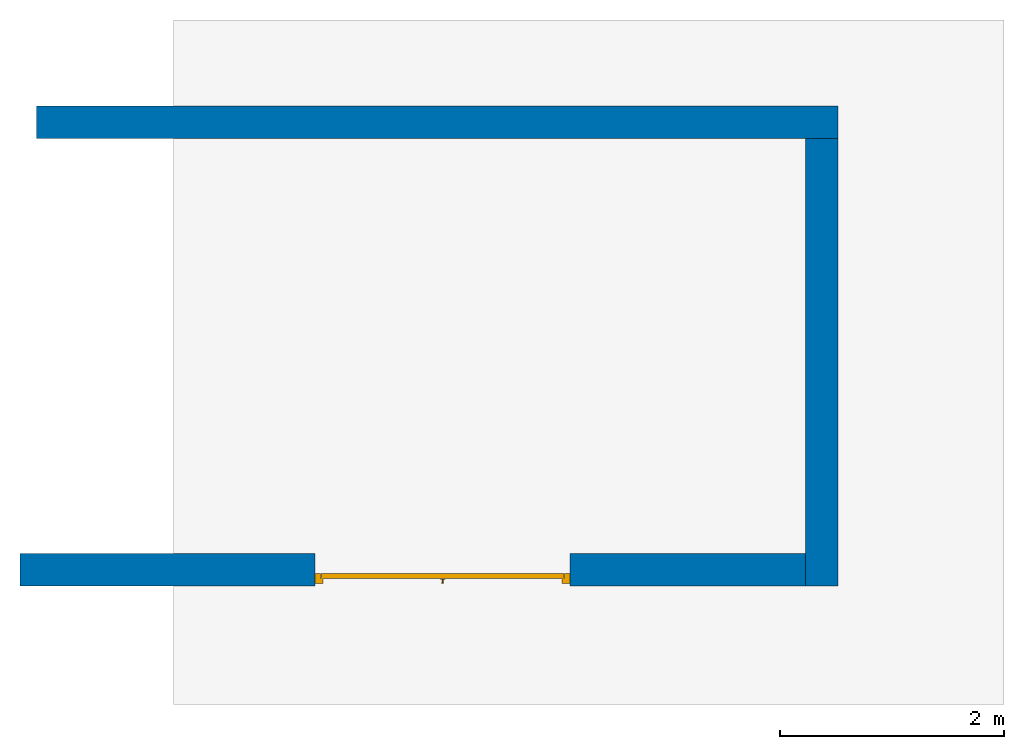
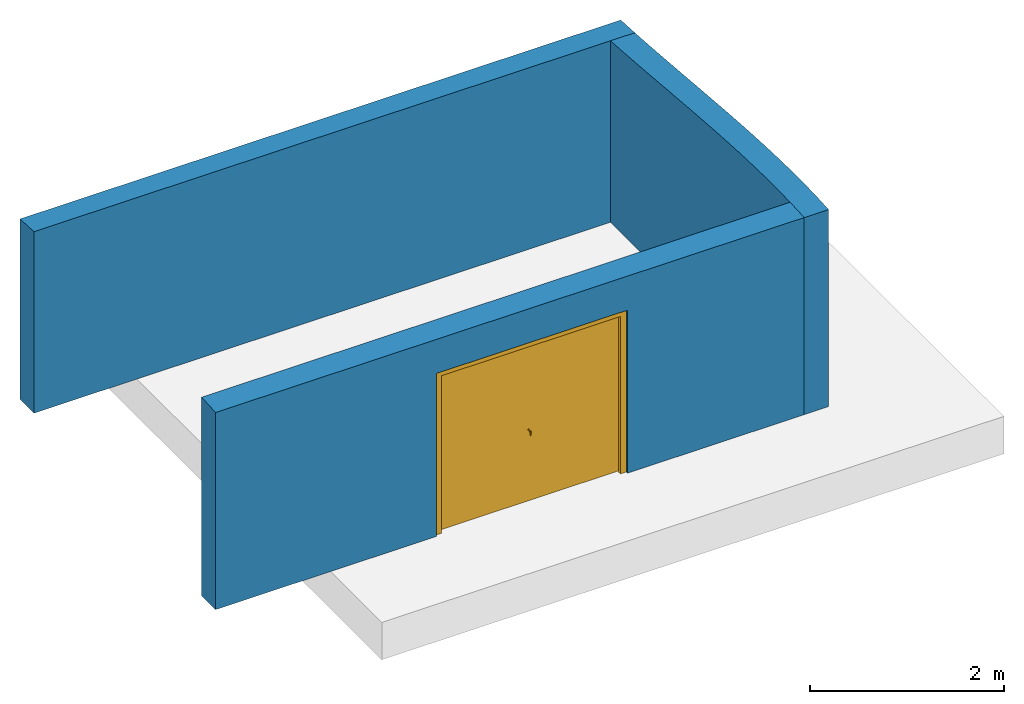
# One storey, part 2 of 2: 3 walls, 1 door, 1 opening.
"""IFC2X3 building model written with IfcOpenShell, lengths in millimetres."""

from ifc_helpers import new_model, entity, si_unit, converted_unit, derived_unit, direction, frame, frame_2d, origin, place, context, subcontext, project, spatial, rectangle, extrude, faceted_brep, source, transform, mapped, material, material_list, type_object, type_shapes, element, fill, save


model = new_model("IFC2X3")

# Units and contexts
model_context = context("Model", 3, precision=0.01, world=origin(), true_north=direction((6.12303176911189e-17, 1.0)))
body_context = subcontext(model_context, "Body", "Model", "MODEL_VIEW")
ifc_project = project(units=[si_unit("LENGTHUNIT", "METRE", prefix="MILLI"), si_unit("AREAUNIT", "SQUARE_METRE"), si_unit("VOLUMEUNIT", "CUBIC_METRE"), converted_unit("PLANEANGLEUNIT", "DEGREE", entity("IfcRatioMeasure", 0.0174532925199433), si_unit("PLANEANGLEUNIT", "RADIAN"), dimensions=[0, 0, 0, 0, 0, 0, 0]), si_unit("MASSUNIT", "GRAM", prefix="KILO"), si_unit("TIMEUNIT", "SECOND"), si_unit("FREQUENCYUNIT", "HERTZ"), si_unit("THERMODYNAMICTEMPERATUREUNIT", "DEGREE_CELSIUS"), derived_unit("THERMALTRANSMITTANCEUNIT", [(si_unit("MASSUNIT", "GRAM", prefix="KILO"), 1), (si_unit("THERMODYNAMICTEMPERATUREUNIT", "KELVIN"), -1), (si_unit("TIMEUNIT", "SECOND"), -3)]), derived_unit("VOLUMETRICFLOWRATEUNIT", [(si_unit("LENGTHUNIT", "METRE"), 3), (si_unit("TIMEUNIT", "SECOND"), -1)]), si_unit("ELECTRICCURRENTUNIT", "AMPERE"), si_unit("ELECTRICVOLTAGEUNIT", "VOLT"), si_unit("POWERUNIT", "WATT"), si_unit("FORCEUNIT", "NEWTON", prefix="KILO"), si_unit("ILLUMINANCEUNIT", "LUX"), si_unit("LUMINOUSFLUXUNIT", "LUMEN"), si_unit("LUMINOUSINTENSITYUNIT", "CANDELA"), derived_unit("USERDEFINED", [(si_unit("MASSUNIT", "GRAM", prefix="KILO"), -1), (si_unit("LENGTHUNIT", "METRE"), -2), (si_unit("TIMEUNIT", "SECOND"), 3), (si_unit("LUMINOUSFLUXUNIT", "LUMEN"), 1)]), derived_unit("LINEARVELOCITYUNIT", [(si_unit("LENGTHUNIT", "METRE"), 1), (si_unit("TIMEUNIT", "SECOND"), -1)]), si_unit("PRESSUREUNIT", "PASCAL"), derived_unit("USERDEFINED", [(si_unit("LENGTHUNIT", "METRE"), -2), (si_unit("MASSUNIT", "GRAM", prefix="KILO"), 1), (si_unit("TIMEUNIT", "SECOND"), -2)])], contexts=[model_context])

# Site, building, storey
site_placement = place(None, origin())
site = spatial("IfcSite", under=ifc_project, at=site_placement, CompositionType="ELEMENT")
building_placement = place(site_placement, origin())
building = spatial("IfcBuilding", under=site, at=building_placement, CompositionType="ELEMENT")
storey_placement = place(building_placement, origin())
storey = spatial("IfcBuildingStorey", under=building, at=storey_placement, Name="Level 0", CompositionType="ELEMENT", Elevation=0.0)

# Walls
ifc_material_1 = material(Name="Brick, Common")
ifc_material_2 = material(Name="Fiberglass Batt")
ifc_material_3 = material(Name="Concrete Masonry Units _Low Density")
ifc_material_4 = material(Name="Plaster")
ifc_material_list_1 = material_list([ifc_material_1, ifc_material_2, ifc_material_3, ifc_material_4])
wall_type = type_object("IfcWallType", PredefinedType="NOTDEFINED")
wall_1_placement = place(storey_placement, frame((7047.64559519153, 1813.63350968312, 0.0)))
element("IfcWall", 1, at=wall_1_placement, inside=storey, type_object=wall_type, material=ifc_material_list_1, context=body_context, shape_type="Brep", body=[
    faceted_brep([(0.0, -145.0, 2281.7914346779), (0.0, -145.0, 0.0), (6855.0, -145.0, 0.0), (7145.0, -145.0, 0.0), (7145.0, -145.0, 2281.7914346779), (6855.0, -145.0, 2281.7914346779), (5394.23421303837, -145.0, 2281.7914346779), (3933.46842607673, -145.0, 2281.7914346779), (2950.10131955755, -145.0, 2281.7914346779), (1966.73421303836, -145.0, 2281.7914346779), (983.367106519185, -145.0, 2281.7914346779), (7145.0, 145.0, 0.0), (0.0, 145.0, 0.0), (0.0, 145.0, 2266.01450915395), (983.367105430462, 145.0, 2266.01450915395), (1966.73421086093, 145.0, 2266.01450915395), (3572.5, 145.0, 2266.01450915395), (5178.26578913908, 145.0, 2266.01450915395), (6161.63289456954, 145.0, 2266.01450915395), (7145.0, 145.0, 2266.01450915395), (0.0, -72.5042682850876, 2277.4048198664), (0.0, -0.0176978591323646, 2273.29703191053), (0.0, 72.4837913931937, 2269.49143553), (7145.0, 72.4955520406726, 2269.49084419756), (7145.0, -0.019433106363573, 2273.2971267219), (7145.0, -72.5178888364432, 2277.40561863594), (1475.0506612011, 1.18072418660527, 2273.23159334814), (2783.83369596127, -0.369299165116482, 2273.31624643556), (5669.94934270946, 6.80500430566447, 2272.92559467043), (4458.30028831694, 9.42253038304246, 2272.78380948582)], [[[0, 1, 2, 3, 4, 5, 6, 7, 8, 9, 10]], [[11, 12, 13, 14, 15, 16, 17, 18, 19]], [[2, 1, 12, 11, 3]], [[1, 0, 20, 21, 22, 13, 12]], [[4, 3, 11, 19, 23, 24, 25]], [[4, 25, 5]], [[26, 9, 27]], [[23, 19, 18]], [[28, 25, 24]], [[15, 26, 27]], [[24, 23, 28]], [[18, 17, 28]], [[14, 26, 15]], [[20, 10, 26]], [[20, 0, 10]], [[10, 9, 26]], [[21, 20, 26]], [[18, 28, 23]], [[27, 16, 15]], [[22, 26, 14]], [[29, 7, 6]], [[22, 14, 13]], [[6, 28, 29]], [[5, 25, 28]], [[22, 21, 26]], [[27, 9, 8, 7]], [[29, 27, 7]], [[28, 17, 29]], [[6, 5, 28]], [[17, 16, 29]], [[27, 29, 16]]]),
])
ifc_material_list_2 = material_list([ifc_material_1, ifc_material_2, ifc_material_3, ifc_material_4])
wall_2_placement = place(storey_placement, frame((14047.6455951915, 1668.6335096831, 0.0), z_axis=(0.0, 0.0, 1.0), x_axis=(0.0, -1.0, 0.0)))
element("IfcWall", 2, at=wall_2_placement, inside=storey, type_object=wall_type, material=ifc_material_list_2, context=body_context, shape_type="Brep", body=[
    faceted_brep([(0.0, -145.0, 2281.7914346779), (0.0, -145.0, 0.0), (3700.0, -145.0, 0.0), (3990.0, -145.0, 0.0), (3990.0, -145.0, 2478.12392704791), (3845.12582443816, -145.0, 2488.04547899979), (3700.0, -145.0, 2495.0933647095), (3481.9398877718, -145.0, 2500.94190301711), (3263.80623411362, -145.0, 2501.89771600336), (3045.69327909423, -145.0, 2498.71301732107), (2827.65979052636, -145.0, 2492.02479273784), (2609.7389546503, -145.0, 2482.38205888179), (2391.94822320244, -145.0, 2470.26579985514), (2174.28042428054, -145.0, 2456.10621247676), (1956.72342666171, -145.0, 2440.29529705378), (1739.26200886923, -145.0, 2423.19657960039), (1521.87562809643, -145.0, 2405.15530210548), (1304.53975118509, -145.0, 2386.5087901134), (1087.22732929095, -145.0, 2367.59285581293), (869.909613761495, -145.0, 2348.74986396616), (652.556678766577, -145.0, 2330.33925358626), (435.138770226233, -145.0, 2312.74851373503), (217.627827221149, -145.0, 2296.40459229184), (3768.31130936702, 145.0, 2492.11458748863), (3990.0, 145.0, 2478.12392704791), (3990.0, 145.0, 0.0), (0.0, 145.0, 0.0), (0.0, 145.0, 2281.7914346779), (221.621756614784, 145.0, 2296.69061935739), (443.154443203553, 145.0, 2313.37755372689), (664.58757150771, 145.0, 2331.34047589612), (885.951655472051, 145.0, 2350.1305130772), (1107.27872742539, 145.0, 2369.34049840267), (1328.60052148352, 145.0, 2388.59265513477), (1549.94681060492, 145.0, 2407.52638935132), (1771.34937114365, 145.0, 2425.7874512519), (1992.836489455, 145.0, 2443.01897661574), (2214.42914490158, 145.0, 2458.85393262736), (2436.14272786769, 145.0, 2472.90364646695), (2657.984973105, 145.0, 2484.74655829807), (2879.95271004624, 145.0, 2493.91797491234), (3102.02737106329, 145.0, 2499.8951201004), (3324.16843908698, 145.0, 2502.07724181026), (3546.30323220058, 145.0, 2499.76216618538), (0.0, -22.4520225769346, 2281.7914346779), (3990.0, -22.4520240103694, 2478.12392704791), (3591.66701505233, -4.65567741795813, 2498.66348940372), (978.342919768752, -1.30145733372609, 2358.12054303388), (1413.1139823256, -1.82700565260529, 2395.87911861027), (3155.22907269487, -3.94120385708587, 2500.78792558884), (1848.0253136245, -2.32222563566622, 2431.8884573719), (2719.00737184876, -3.34639800863847, 2487.55562102566), (2283.27800138095, -2.81852666637113, 2463.42774903567), (543.476683490911, -0.708759376216587, 2321.38495640703), (268.54072478163, -10.2020142300845, 2300.09335419872)], [[[0, 1, 2, 3, 4, 5, 6, 7, 8, 9, 10, 11, 12, 13, 14, 15, 16, 17, 18, 19, 20, 21, 22]], [[23, 24, 25, 26, 27, 28, 29, 30, 31, 32, 33, 34, 35, 36, 37, 38, 39, 40, 41, 42, 43]], [[2, 1, 26, 25, 3]], [[26, 1, 0, 44, 27]], [[4, 3, 25, 24, 45]], [[43, 46, 23]], [[47, 18, 48]], [[49, 46, 42]], [[14, 13, 50]], [[51, 10, 9]], [[52, 12, 11]], [[36, 52, 37]], [[16, 15, 50]], [[45, 24, 23]], [[5, 4, 45]], [[52, 51, 38]], [[39, 51, 40]], [[52, 38, 37]], [[51, 49, 40]], [[53, 20, 47]], [[41, 49, 42]], [[29, 54, 53]], [[46, 5, 45]], [[46, 49, 7]], [[7, 6, 46]], [[46, 45, 23]], [[28, 44, 54]], [[49, 51, 9]], [[9, 8, 49]], [[51, 11, 10]], [[51, 52, 11]], [[52, 13, 12]], [[52, 36, 50]], [[46, 43, 42]], [[48, 32, 47]], [[30, 47, 31]], [[32, 48, 33]], [[50, 35, 34]], [[48, 50, 34]], [[35, 50, 36]], [[48, 34, 33]], [[51, 39, 38]], [[0, 22, 44]], [[49, 41, 40]], [[54, 29, 28]], [[49, 8, 7]], [[29, 53, 30]], [[47, 30, 53]], [[6, 5, 46]], [[22, 54, 44]], [[27, 44, 28]], [[31, 47, 32]], [[16, 48, 17]], [[50, 15, 14]], [[48, 16, 50]], [[18, 17, 48]], [[53, 21, 20]], [[19, 18, 47]], [[19, 47, 20]], [[21, 53, 54]], [[21, 54, 22]], [[13, 52, 50]]]),
])

# Wall, opening, door
ifc_material_list_3 = material_list([ifc_material_1, ifc_material_2, ifc_material_3, ifc_material_4])
wall_3_placement = place(storey_placement, frame((13902.6455951915, -2176.36649031687, 0.0), z_axis=(0.0, 0.0, 1.0), x_axis=(-1.0, 0.0, 0.0)))
wall_3 = element("IfcWall", 3, at=wall_3_placement, inside=storey, type_object=wall_type, material=ifc_material_list_3, context=body_context, shape_type="Brep", body=[
    faceted_brep([(7000.0, -145.0, 0.0), (4370.0, -145.0, 0.0), (4370.0, 145.0, 0.0), (7000.0, 145.0, 0.0), (2100.0, -145.0, 0.0), (0.0, -145.0, 0.0), (0.0, 145.0, 0.0), (2100.0, 145.0, 0.0), (2100.0, -145.0, 2050.0), (4370.0, -145.0, 2050.0), (7000.0, -145.0, 2495.0933647095), (6033.05390797316, -145.0, 2495.0933647095), (5066.10781594632, -145.0, 2495.0933647095), (3500.0, -145.0, 2495.0933647095), (1933.89218405369, -145.0, 2495.0933647095), (966.946092026843, -145.0, 2495.0933647095), (0.0, -145.0, 2495.0933647095), (4370.0, 145.0, 2050.0), (2100.0, 145.0, 2050.0), (0.0, 145.0, 2478.12392704791), (966.94609896195, 145.0, 2478.12392704791), (1933.8921979239, 145.0, 2478.12392704791), (3132.21560415221, 145.0, 2478.12392704791), (4099.16170311416, 145.0, 2478.12392704791), (5066.10780207611, 145.0, 2478.12392704791), (6033.05390103806, 145.0, 2478.12392704791), (7000.0, 145.0, 2478.12392704791), (7000.0, 72.5919504889502, 2483.46536386546), (7000.0, 0.100203628499192, 2488.04696832332), (7000.0, -72.4334402519563, 2491.90949614257), (0.0, -72.4172015023469, 2491.90870900421), (0.0, 0.102346444653849, 2488.04684376605), (0.0, 72.5782633228344, 2483.46629977861), (4252.35899594271, 4.78369868787154, 2487.77322122093), (5549.58084483601, 1.52233955613148, 2487.96416408263), (2651.08339095091, -8.08225936188257, 2488.51801461218), (1450.41913102682, 1.5223378895987, 2487.96416417982)], [[[0, 1, 2, 3]], [[4, 5, 6, 7]], [[5, 4, 8, 9, 1, 0, 10, 11, 12, 13, 14, 15, 16]], [[3, 2, 17, 18, 7, 6, 19, 20, 21, 22, 23, 24, 25, 26]], [[10, 0, 3, 26, 27, 28, 29]], [[16, 30, 31, 32, 19, 6, 5]], [[33, 12, 34]], [[29, 34, 11]], [[32, 20, 19]], [[21, 35, 22]], [[15, 14, 36]], [[11, 34, 12]], [[36, 32, 31]], [[30, 16, 15]], [[36, 30, 15]], [[27, 34, 28]], [[25, 24, 34]], [[20, 36, 21]], [[12, 33, 13]], [[31, 30, 36]], [[21, 36, 35]], [[29, 11, 10]], [[34, 27, 25]], [[27, 26, 25]], [[29, 28, 34]], [[34, 24, 33]], [[14, 35, 36]], [[36, 20, 32]], [[33, 24, 23, 22]], [[35, 33, 22]], [[14, 13, 35]], [[33, 35, 13]], [[7, 18, 8, 4]], [[17, 2, 1, 9]], [[18, 17, 9, 8]]]),
])
opening_placement = place(wall_3_placement, frame((4370.0, 145.0, 0.0)))
opening = element("IfcOpeningElement", 4, at=opening_placement, cuts=wall_3, Name="Doors_Garage_Horz_Pnl:2270x2050mm:1", ObjectType="Opening", context=body_context, shape_type="SweptSolid", body=[
    extrude(rectangle(XDim=2050.0, YDim=2270.0, at=frame_2d((1025.0, 1135.0), x_axis=(-1.0, 0.0))), frame((0.0, 0.0, 0.0), z_axis=(0.0, -1.0, 0.0), x_axis=(0.0, 0.0, 1.0)), (0.0, 0.0, 1.0), 290.0),
])
ifc_material_5 = material(Name="Door - Handle")
ifc_material_6 = material(Name="Door - Panel")
ifc_material_7 = material(Name="Door - Frame/Mullion")
ifc_material_list_4 = material_list([ifc_material_5, ifc_material_6, ifc_material_7])
ifc_material_list_5 = material_list([ifc_material_5, ifc_material_6, ifc_material_7])
door_style = type_object("IfcDoorStyle", Name="2270x2050mm", ConstructionType="NOTDEFINED", OperationType="ROLLINGUP", ParameterTakesPrecedence=False, Sizeable=False, material=ifc_material_list_5)
shared_shape = source(origin(), body_context, "Body", "Brep", [
    faceted_brep([(1145.0, 225.0, 882.679491924314), (1149.14213562373, 225.0, 885.857864376271), (1152.32050807569, 225.0, 890.0), (1154.31851652578, 225.0, 894.823619097952), (1155.0, 225.0, 900.0), (1154.31851652578, 225.0, 905.176380902053), (1152.32050807569, 225.0, 910.0), (1149.14213562373, 225.0, 914.142135623733), (1145.0, 225.0, 917.320508075691), (1140.17638090205, 225.0, 919.318516525784), (1135.0, 225.0, 920.0), (1129.82361909795, 225.0, 919.318516525784), (1125.0, 225.0, 917.320508075691), (1120.85786437627, 225.0, 914.142135623733), (1117.67949192431, 225.0, 910.0), (1115.68148347422, 225.0, 905.176380902053), (1115.0, 225.0, 900.0), (1115.68148347422, 225.0, 894.823619097952), (1117.67949192431, 225.0, 890.0), (1120.85786437627, 225.0, 885.857864376272), (1125.0, 225.0, 882.679491924314), (1129.82361909795, 225.0, 880.681483474221), (1135.0, 225.0, 880.0), (1140.17638090205, 225.0, 880.681483474221), (1129.82361909795, 228.0, 919.318516525784), (1135.0, 228.0, 920.0), (1140.17638090205, 228.0, 919.318516525784), (1145.0, 228.0, 917.320508075691), (1149.14213562373, 228.0, 914.142135623733), (1152.32050807569, 228.0, 910.0), (1154.31851652578, 228.0, 905.176380902053), (1155.0, 228.0, 900.0), (1154.31851652578, 228.0, 894.823619097952), (1152.32050807569, 228.0, 890.0), (1149.14213562373, 228.0, 885.857864376271), (1145.0, 228.0, 882.679491924314), (1140.17638090205, 228.0, 880.681483474221), (1135.0, 228.0, 880.0), (1129.82361909795, 228.0, 880.681483474221), (1125.0, 228.0, 882.679491924314), (1120.85786437627, 228.0, 885.857864376272), (1117.67949192431, 228.0, 890.0), (1115.68148347422, 228.0, 894.823619097952), (1115.0, 228.0, 900.0), (1115.68148347422, 228.0, 905.176380902053), (1117.67949192431, 228.0, 910.0), (1120.85786437627, 228.0, 914.142135623733), (1125.0, 228.0, 917.320508075691)], [[[0, 1, 2, 3, 4, 5, 6, 7, 8, 9, 10, 11, 12, 13, 14, 15, 16, 17, 18, 19, 20, 21, 22, 23]], [[24, 25, 26, 27, 28, 29, 30, 31, 32, 33, 34, 35, 36, 37, 38, 39, 40, 41, 42, 43, 44, 45, 46, 47]], [[42, 17, 16, 43]], [[41, 18, 17, 42]], [[20, 19, 40, 39]], [[41, 40, 19, 18]], [[21, 20, 39, 38]], [[22, 21, 38, 37]], [[36, 23, 22, 37]], [[35, 0, 23, 36]], [[2, 1, 34, 33]], [[35, 34, 1, 0]], [[3, 2, 33, 32]], [[4, 3, 32, 31]], [[30, 5, 4, 31]], [[29, 6, 5, 30]], [[8, 7, 28, 27]], [[29, 28, 7, 6]], [[9, 8, 27, 26]], [[10, 9, 26, 25]], [[24, 11, 10, 25]], [[47, 12, 11, 24]], [[14, 13, 46, 45]], [[47, 46, 13, 12]], [[15, 14, 45, 44]], [[16, 15, 44, 43]]]),
    faceted_brep([(1136.36052136253, 258.0, 844.503115749081), (1136.84925724535, 258.0, 845.211361339245), (1141.52469684716, 258.0, 863.486560834333), (1143.65961471889, 258.0, 871.831455290089), (1145.95097945187, 258.0, 899.213201372643), (1145.62894513629, 258.0, 901.659294849666), (1144.68478829596, 258.0, 903.938691098591), (1143.18285165927, 258.0, 905.896053031933), (1141.22548972593, 258.0, 907.397989668629), (1138.946093477, 258.0, 908.342146508956), (1136.49999999998, 258.0, 908.664180824539), (1135.0, 258.0, 908.664180824539), (1133.50000000001, 258.0, 908.664180824539), (1131.05390652299, 258.0, 908.342146508956), (1128.77451027406, 258.0, 907.397989668629), (1126.81714834072, 258.0, 905.896053031933), (1125.31521170402, 258.0, 903.938691098591), (1124.3710548637, 258.0, 901.659294849666), (1124.0490205481, 258.0, 899.213201372642), (1125.62208590574, 258.0, 880.415113240384), (1126.3403852811, 258.0, 871.831455290089), (1128.47530315287, 258.0, 863.486560834136), (1133.15074275464, 258.0, 845.211361339248), (1133.63947863801, 258.0, 844.503115748288), (1133.86121013507, 258.0, 844.181796277957), (1134.2752341592, 258.0, 843.993609467048), (1135.0, 258.0, 843.664180824536), (1135.72476583902, 258.0, 843.993609466242), (1136.13878986491, 258.0, 844.181796277956), (1134.92195402929, 259.454991588711, 844.505390381415), (1133.89693486175, 258.746192107091, 845.211361339248), (1136.10306513847, 258.746192106861, 845.211361339248), (1135.0, 259.849257245332, 845.211361339248), (1135.0, 267.320526259636, 876.092215256406), (1129.52451027405, 267.483826401641, 899.213201372642), (1135.0, 264.71403550519, 862.090002961909), (1140.47548972594, 267.483826401641, 899.213201372642), (1135.0, 266.99796610106, 904.966593150274), (1135.0, 263.340411394938, 907.848724108267), (1135.0, 259.49999999996, 908.664180824539)], [[[0, 1, 2, 3, 4, 5, 6, 7, 8, 9, 10, 11, 12, 13, 14, 15, 16, 17, 18, 19, 20, 21, 22, 23, 24, 25, 26, 27, 28]], [[23, 29, 24]], [[27, 26, 25]], [[23, 22, 30]], [[31, 0, 29]], [[23, 30, 29]], [[30, 32, 29]], [[0, 28, 29]], [[29, 28, 27]], [[29, 32, 31]], [[31, 1, 0]], [[29, 27, 25]], [[24, 29, 25]], [[33, 19, 34]], [[20, 19, 33]], [[4, 3, 33]], [[22, 21, 20, 35]], [[35, 33, 3]], [[1, 35, 3, 2]], [[34, 36, 33]], [[19, 18, 34]], [[35, 1, 31, 32]], [[4, 33, 36]], [[35, 32, 30, 22]], [[33, 35, 20]], [[5, 36, 37]], [[4, 36, 5]], [[7, 6, 37]], [[8, 38, 9]], [[37, 38, 7]], [[10, 9, 39]], [[34, 37, 36]], [[34, 18, 17]], [[16, 37, 17]], [[15, 37, 16]], [[38, 39, 9]], [[37, 15, 38]], [[13, 12, 39]], [[13, 38, 14]], [[38, 8, 7]], [[39, 38, 13]], [[6, 5, 37]], [[17, 37, 34]], [[38, 15, 14]], [[39, 12, 11, 10]]]),
    faceted_brep([(1128.93782217351, 258.0, 896.500000000003), (1128.23851921597, 258.0, 898.188266684285), (1128.0, 258.0, 900.0), (1128.23851921597, 258.0, 901.81173331572), (1128.93782217351, 258.0, 903.500000000003), (1130.05025253169, 258.0, 904.949747468308), (1131.5, 258.0, 906.062177826494), (1133.18826668428, 258.0, 906.761480784026), (1135.0, 258.0, 907.0), (1136.81173331571, 258.0, 906.761480784026), (1138.5, 258.0, 906.062177826494), (1139.9497474683, 258.0, 904.949747468308), (1141.06217782649, 258.0, 903.500000000003), (1141.76148078402, 258.0, 901.81173331572), (1142.0, 258.0, 900.0), (1141.76148078402, 258.0, 898.188266684285), (1141.06217782649, 258.0, 896.500000000003), (1139.9497474683, 258.0, 895.050252531697), (1138.5, 258.0, 893.937822173511), (1136.81173331571, 258.0, 893.238519215979), (1135.0, 258.0, 893.0), (1133.18826668428, 258.0, 893.238519215979), (1131.5, 258.0, 893.937822173511), (1130.05025253169, 258.0, 895.050252531697), (1128.93782217351, 228.0, 903.500000000003), (1128.23851921597, 228.0, 901.81173331572), (1128.0, 228.0, 900.0), (1128.23851921597, 228.0, 898.188266684285), (1128.93782217351, 228.0, 896.500000000003), (1130.05025253169, 228.0, 895.050252531697), (1131.5, 228.0, 893.937822173511), (1133.18826668428, 228.0, 893.238519215979), (1135.0, 228.0, 893.0), (1136.81173331571, 228.0, 893.238519215979), (1138.5, 228.0, 893.937822173511), (1139.9497474683, 228.0, 895.050252531697), (1141.06217782649, 228.0, 896.500000000003), (1141.76148078402, 228.0, 898.188266684285), (1142.0, 228.0, 900.0), (1141.76148078402, 228.0, 901.81173331572), (1141.06217782649, 228.0, 903.500000000003), (1139.9497474683, 228.0, 904.949747468308), (1138.5, 228.0, 906.062177826494), (1136.81173331571, 228.0, 906.761480784026), (1135.0, 228.0, 907.0), (1133.18826668428, 228.0, 906.761480784026), (1131.5, 228.0, 906.062177826494), (1130.05025253169, 228.0, 904.949747468308)], [[[0, 1, 2, 3, 4, 5, 6, 7, 8, 9, 10, 11, 12, 13, 14, 15, 16, 17, 18, 19, 20, 21, 22, 23]], [[24, 25, 26, 27, 28, 29, 30, 31, 32, 33, 34, 35, 36, 37, 38, 39, 40, 41, 42, 43, 44, 45, 46, 47]], [[37, 15, 14, 38]], [[36, 16, 15, 37]], [[18, 17, 35, 34]], [[36, 35, 17, 16]], [[19, 18, 34, 33]], [[20, 19, 33, 32]], [[31, 21, 20, 32]], [[30, 22, 21, 31]], [[0, 23, 29, 28]], [[30, 29, 23, 22]], [[1, 0, 28, 27]], [[2, 1, 27, 26]], [[25, 3, 2, 26]], [[24, 4, 3, 25]], [[6, 5, 47, 46]], [[24, 47, 5, 4]], [[7, 6, 46, 45]], [[8, 7, 45, 44]], [[43, 9, 8, 44]], [[42, 10, 9, 43]], [[12, 11, 41, 40]], [[42, 41, 11, 10]], [[13, 12, 40, 39]], [[14, 13, 39, 38]]]),
    faceted_brep([(2218.49999999999, 176.0, 10.0), (2218.49999999999, 176.0, 1998.49999999997), (51.500000000001, 176.0, 1998.49999999997), (51.5000000000012, 176.0, 10.0), (2218.49999999999, 220.0, 10.0), (2218.49999999999, 220.0, 1998.49999999997), (51.500000000001, 220.0, 1998.49999999997), (51.5000000000013, 220.0, 10.0)], [[[0, 1, 2, 3]], [[1, 0, 4, 5]], [[3, 2, 6, 7]], [[0, 3, 7, 4]], [[4, 7, 6, 5]], [[2, 1, 5, 6]]]),
    faceted_brep([(2199.49999999999, 265.0, 0.0), (2270.0, 265.0, 0.0), (2270.0, 176.0, 0.0), (2221.49999999999, 176.0, 0.0), (2221.49999999999, 223.0, 0.0), (2199.49999999999, 223.0, 0.0), (2199.49999999999, 265.0, 1979.49999999998), (70.5000000000014, 265.0, 1979.49999999998), (70.5000000000017, 265.0, 0.0), (0.0, 265.0, 0.0), (0.0, 265.0, 2050.0), (2270.0, 265.0, 2050.0), (2270.0, 176.0, 2050.0), (0.0, 176.0, 2050.0), (0.0, 176.0, 0.0), (48.5000000000037, 176.0, 0.0), (48.5000000000037, 176.0, 2001.49999999997), (2221.49999999999, 176.0, 2001.49999999997), (2221.49999999999, 223.0, 2001.49999999997), (48.5000000000039, 223.0, 2001.49999999997), (48.5000000000037, 223.0, 0.0), (70.5000000000017, 223.0, 0.0), (70.5000000000016, 223.0, 1979.49999999998), (2199.49999999999, 223.0, 1979.49999999998)], [[[0, 1, 2, 3, 4, 5]], [[1, 0, 6, 7, 8, 9, 10, 11]], [[2, 1, 11, 12]], [[3, 2, 12, 13, 14, 15, 16, 17]], [[4, 3, 17, 18]], [[5, 4, 18, 19, 20, 21, 22, 23]], [[0, 5, 23, 6]], [[7, 22, 21, 8]], [[8, 21, 20, 15, 14, 9]], [[13, 10, 9, 14]], [[19, 16, 15, 20]], [[12, 11, 10, 13]], [[18, 17, 16, 19]], [[6, 23, 22, 7]]]),
])
type_shapes(door_style, [shared_shape])
door_placement = place(opening_placement, frame((-2270.0, -290.0, 0.0)))
door = element("IfcDoor", 5, at=door_placement, inside=storey, type_object=door_style, material=ifc_material_list_4, Name="Doors_Garage_Horz_Pnl:2270x2050mm", ObjectType="2270x2050mm", OverallHeight=2050.0, OverallWidth=2270.0, context=body_context, shape_type="MappedRepresentation", body=[
    mapped(shared_shape, transform((0.0, 0.0, 0.0), scale=1.0)),
])
fill(opening, door)

save(model, "model.ifc")
